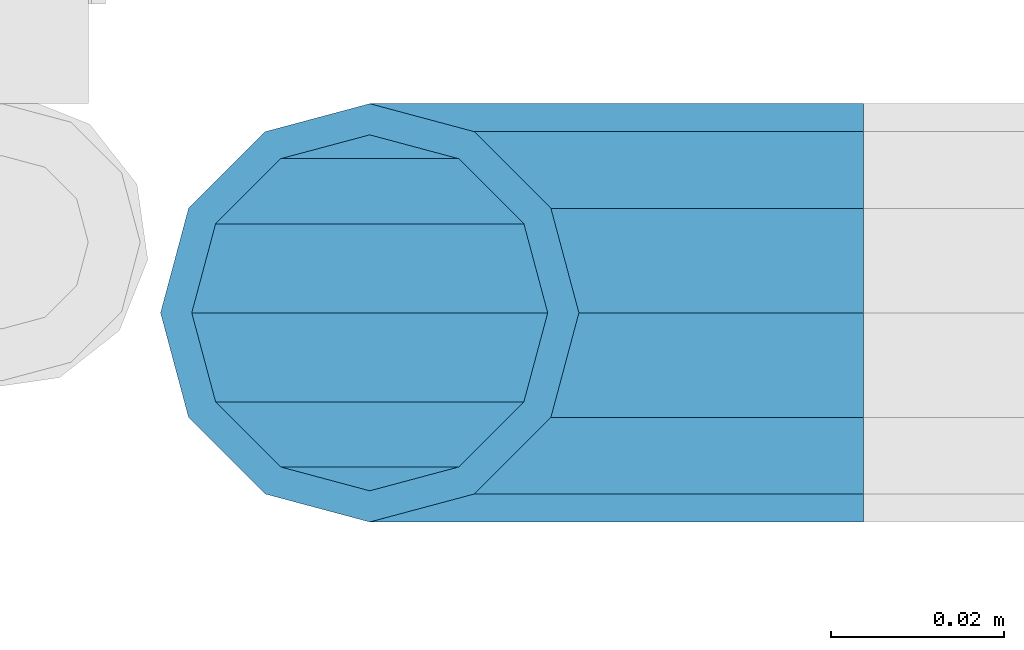
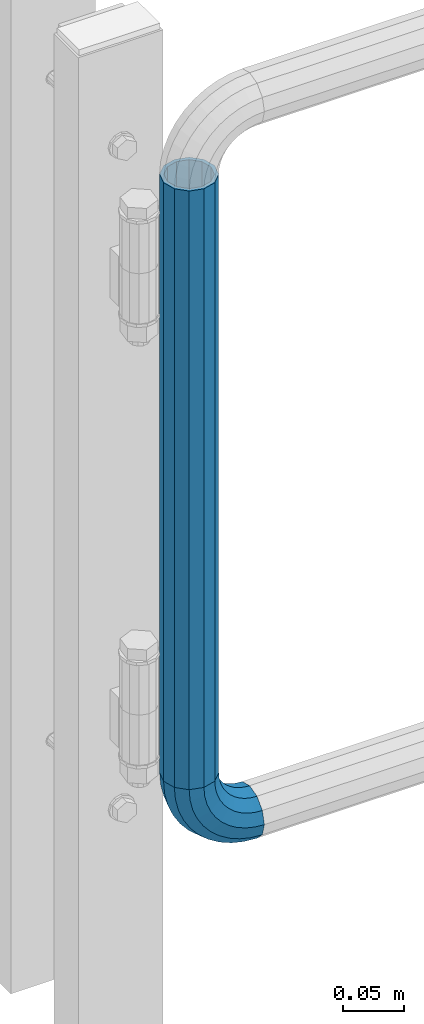
# One storey, part 177 of 247: 1 beam, 1 member.
"""IFC2X3 building model written with IfcOpenShell, lengths in millimetres."""

from ifc_helpers import new_model, si_unit, frame, origin_with_axes, place, context, subcontext, project, spatial, faceted_brep, material, type_object, element, save


model = new_model("IFC2X3")

# Units and contexts
model_context = context("Model", 3, precision=1e-05, world=origin_with_axes())
body_context = subcontext(model_context, "Body", "Model", "MODEL_VIEW")
ifc_project = project(units=[si_unit("LENGTHUNIT", "METRE", prefix="MILLI"), si_unit("AREAUNIT", "SQUARE_METRE"), si_unit("VOLUMEUNIT", "CUBIC_METRE"), si_unit("MASSUNIT", "GRAM", prefix="KILO"), si_unit("TIMEUNIT", "SECOND"), si_unit("PLANEANGLEUNIT", "RADIAN"), si_unit("SOLIDANGLEUNIT", "STERADIAN"), si_unit("THERMODYNAMICTEMPERATUREUNIT", "DEGREE_CELSIUS"), si_unit("LUMINOUSINTENSITYUNIT", "LUMEN")], contexts=[model_context])

# Site, building, storey
site_placement = place(None, origin_with_axes())
site = spatial("IfcSite", under=ifc_project, at=site_placement, CompositionType="ELEMENT")
building_placement = place(site_placement, origin_with_axes())
building = spatial("IfcBuilding", under=site, at=building_placement, Name="Standard", CompositionType="ELEMENT")
storey_placement = place(building_placement, origin_with_axes())
storey = spatial("IfcBuildingStorey", under=building, at=storey_placement, Name="Undefined", CompositionType="ELEMENT", Elevation=0.0)

# Member
ifc_material = material()
member_type = type_object("IfcMemberType", PredefinedType="NOTDEFINED")
member_placement = place(storey_placement, frame((26955.2462679207, 8941.85337247848, 224.650000000007), z_axis=(0.0, -0.999999999999548, -9.5100000000016e-07), x_axis=(-0.707106789186492, 3.85000008583224e-07, 0.707106773186498)))
element("IfcMember", 1, at=member_placement, inside=storey, type_object=member_type, material=ifc_material, context=body_context, shape_type="Brep", body=[
    faceted_brep([(17.0766287656552, -17.0766287656515, 0.0), (14.7887943220521, -14.7887943220485, -12.0749999999998), (19.0945697419556, -11.1113146999705, -12.0749999999998), (20.9963409898264, -13.7288782624128, 0.0), (8.53831438282941, -8.53831438282577, -20.9145135013941), (13.8988340683936, -3.95999805533575, -20.9145135013941), (0.0, 3.63797880709171e-12, -24.1499999999996), (6.80132714696083, 5.80888215174127, -24.1499999999996), (-8.53831438282577, 8.53831438282941, -20.9145135013941), (-0.296179774468328, 15.5777623588219, -20.9145135013941), (-14.7887943220521, 14.7887943220558, -12.0749999999998), (-5.4919154480267, 22.7290790034531, -12.0749999999998), (-17.0766287656552, 17.0766287656588, 0.0), (-7.39368669590112, 25.3466425658989, 0.0), (-14.7887943220521, 14.7887943220558, 12.0749999999998), (-5.4919154480267, 22.7290790034531, 12.0749999999998), (-8.53831438282577, 8.53831438282941, 20.9145135013941), (-0.296179774468328, 15.5777623588219, 20.9145135013941), (0.0, 3.63797880709171e-12, 24.1499999999996), (6.80132714696083, 5.80888215174127, 24.1499999999996), (8.53831438282941, -8.53831438282577, 20.9145135013941), (13.8988340683936, -3.95999805533575, 20.9145135013941), (14.7887943220521, -14.7887943220485, 12.0749999999998), (19.0945697419556, -11.1113146999705, 12.0749999999998), (14.5310443533854, -14.5310443533817, 0.0), (12.5842535535485, -12.5842535535448, 10.2749999999996), (17.2620366843148, -8.58904933077429, 10.2749999999996), (18.8803140815726, -10.8164170826603, 0.0), (7.26552217669087, -7.26552217668723, 17.7968220477705), (12.8408206142667, -2.50376746545953, 17.7968220477705), (0.0, 3.63797880709171e-12, 20.5500000000002), (6.80132714696083, 5.80888215174127, 20.5500000000002), (-7.26552217669087, 7.2655221766945, 17.7968220477705), (0.761833679654956, 14.1215317689421, 17.7968220477705), (-12.5842535535485, 12.5842535535521, 10.2749999999996), (-3.65938239038951, 20.2068136342532, 10.2749999999996), (-14.5310443533817, 14.5310443533854, 0.0), (-5.27765978764728, 22.4341813861465, 0.0), (-12.5842535535485, 12.5842535535521, -10.2749999999996), (-3.65938239038951, 20.2068136342532, -10.2749999999996), (-7.26552217669087, 7.2655221766945, -17.7968220477705), (0.761833679654956, 14.1215317689421, -17.7968220477705), (0.0, 3.63797880709171e-12, -20.5500000000002), (6.80132714696083, 5.80888215174127, -20.5500000000002), (7.26552217669087, -7.26552217668723, -17.7968220477705), (12.8408206142667, -2.50376746545953, -17.7968220477705), (12.5842535535485, -12.5842535535448, -10.2749999999996), (17.2620366843148, -8.58904933077429, -10.2749999999996), (23.922618478784, -8.15268262886457, -12.0749999999998), (25.3914986111849, -11.0355222080434, 0.0), (19.9095633268335, -0.276618428470101, -20.9145135013941), (14.4276280424783, 10.4822853511068, -24.1499999999996), (8.94569275812319, 21.2411891306838, -20.9145135013941), (4.93263760616901, 29.1172533310746, -12.0749999999998), (3.46375747376806, 32.0000929102534, 0.0), (4.93263760616901, 29.1172533310746, 12.0749999999998), (8.94569275812319, 21.2411891306838, 20.9145135013941), (14.4276280424783, 10.4822853511068, 24.1499999999996), (19.9095633268335, -0.276618428470101, 20.9145135013941), (23.922618478784, -8.15268262886457, 12.0749999999998), (22.5072161777207, -5.37479920327678, 10.2749999999996), (23.7571328121303, -7.82789872096328, 0.0), (19.0923804273007, 1.32719331506814, 17.7968220477705), (14.4276280424783, 10.4822853511068, 20.5500000000002), (9.76287565765597, 19.6373773871455, 17.7968220477705), (6.34803990723594, 26.3393699054905, 10.2749999999996), (5.09812327282998, 28.7924694231733, 0.0), (6.34803990723594, 26.3393699054905, -10.2749999999996), (9.76287565765597, 19.6373773871455, -17.7968220477705), (14.4276280424783, 10.4822853511068, -20.5500000000002), (19.0923804273007, 1.32719331506814, -17.7968220477705), (22.5072161777207, -5.37479920327678, -10.2749999999996), (29.1540579492757, -5.98574944944994, -12.0749999999998), (30.1538782624157, -9.0628799673359, 0.0), (26.4224980553372, 2.42112746692874, -20.9145135013941), (22.6911178482587, 13.9051349011934, -24.1499999999996), (18.9597376411839, 25.3891423354544, -20.9145135013941), (16.228177747249, 33.7960192518367, -12.0749999999998), (15.2283574341054, 36.873149769719, 0.0), (16.228177747249, 33.7960192518367, 12.0749999999998), (18.9597376411839, 25.3891423354544, 20.9145135013941), (22.6911178482587, 13.9051349011934, 24.1499999999996), (26.4224980553372, 2.42112746692874, 20.9145135013941), (29.1540579492757, -5.98574944944994, 12.0749999999998), (28.190638306889, -3.02064867668378, 10.2749999999996), (29.0414170826662, -5.63907650866895, 0.0), (25.8662674654624, 4.13302919626221, 17.7968220477705), (22.6911178482587, 13.9051349011934, 20.5500000000002), (19.5159682310587, 23.6772406061282, 17.7968220477705), (17.1915973896357, 30.8309184790705, 10.2749999999996), (16.3408186138549, 33.4493463110593, 0.0), (17.1915973896357, 30.8309184790705, -10.2749999999996), (19.5159682310587, 23.6772406061282, -17.7968220477705), (22.6911178482587, 13.9051349011934, -20.5500000000002), (25.8662674654624, 4.13302919626221, -17.7968220477705), (28.190638306889, -3.02064867668378, -10.2749999999996), (34.660072751507, -4.66387224825303, -12.0749999999998), (35.1662143510621, -7.85952453907885, 0.0), (33.2772681857023, 4.06681217360529, -20.9145135013941), (31.3883220203388, 15.9931488862931, -24.1499999999996), (29.499375854979, 27.9194855989772, -20.9145135013941), (28.1165712891707, 36.6501700208391, -12.0749999999998), (27.6104296896192, 39.8458223116686, 0.0), (28.1165712891707, 36.6501700208391, 12.0749999999998), (29.499375854979, 27.9194855989772, 20.9145135013941), (31.3883220203388, 15.9931488862931, 24.1499999999996), (33.2772681857023, 4.06681217360529, 20.9145135013941), (34.660072751507, -4.66387224825303, 12.0749999999998), (34.1723583567982, -1.58456474993727, 10.2749999999996), (34.6030502769172, -4.30384651293571, 0.0), (32.995686148628, 5.84465118667504, 17.7968220477705), (31.3883220203388, 15.9931488862931, 20.5500000000002), (29.7809578920533, 26.1416465859074, 17.7968220477705), (28.6042856838794, 33.5708625225234, 10.2749999999996), (28.1735937637641, 36.2901442855255, 0.0), (28.6042856838794, 33.5708625225234, -10.2749999999996), (29.7809578920533, 26.1416465859074, -17.7968220477705), (31.3883220203388, 15.9931488862931, -20.5500000000002), (32.995686148628, 5.84465118667504, -17.7968220477705), (34.1723583567982, -1.58456474993727, -10.2749999999996), (40.3050865276309, -4.21960002902415, -12.0749999999998), (40.3050865276346, -7.45508652763237, 0.0), (40.3050865276309, 4.61991347236835, -20.9145135013941), (40.3050865276346, 16.6949134723691, -24.1499999999996), (40.3050865276309, 28.7699134723698, -20.9145135013941), (40.3050865276309, 37.6094269737623, -12.0749999999998), (40.3050865276346, 40.8449134723705, 0.0), (40.3050865276309, 37.6094269737623, 12.0749999999998), (40.3050865276309, 28.7699134723698, 20.9145135013941), (40.3050865276346, 16.6949134723691, 24.1499999999996), (40.3050865276309, 4.61991347236835, 20.9145135013941), (40.3050865276309, -4.21960002902415, 12.0749999999998), (40.3050865276346, -1.10190857540147, 10.2749999999996), (40.3050865276309, -3.85508652763019, 0.0), (40.3050865276346, 6.41991347236763, 17.7968220477705), (40.3050865276346, 16.6949134723691, 20.5500000000002), (40.3050865276346, 26.9699134723705, 17.7968220477705), (40.3050865276346, 34.4917355201396, 10.2749999999996), (40.3050865276309, 37.2449134723684, 0.0), (40.3050865276346, 34.4917355201396, -10.2749999999996), (40.3050865276346, 26.9699134723705, -17.7968220477705), (40.3050865276346, 16.6949134723691, -20.5500000000002), (40.3050865276346, 6.41991347236763, -17.7968220477705), (40.3050865276346, -1.10190857540147, -10.2749999999996), (45.9501003037585, -4.66387224825667, -12.0749999999998), (45.443958704207, -7.85952453907885, 0.0), (47.3329048695668, 4.06681217360529, -20.9145135013941), (49.2218510349267, 15.9931488862894, -24.1499999999996), (51.1107972002865, 27.9194855989808, -20.9145135013941), (52.4936017660912, 36.6501700208391, -12.0749999999998), (52.9997433656463, 39.845822311665, 0.0), (52.4936017660912, 36.6501700208391, 12.0749999999998), (51.1107972002865, 27.9194855989808, 20.9145135013941), (49.2218510349267, 15.9931488862894, 24.1499999999996), (47.3329048695668, 4.06681217360529, 20.9145135013941), (45.9501003037585, -4.66387224825667, 12.0749999999998), (46.4378146984673, -1.58456474993363, 10.2749999999996), (46.0071227783483, -4.30384651293934, 0.0), (47.6144869066338, 5.84465118667504, 17.7968220477705), (49.2218510349267, 15.9931488862894, 20.5500000000002), (50.8292151632122, 26.1416465859038, 17.7968220477705), (52.0058873713861, 33.5708625225197, 10.2749999999996), (52.4365792915014, 36.2901442855218, 0.0), (52.0058873713861, 33.5708625225197, -10.2749999999996), (50.8292151632122, 26.1416465859038, -17.7968220477705), (49.2218510349267, 15.9931488862894, -20.5500000000002), (47.6144869066338, 5.84465118667504, -17.7968220477705), (46.4378146984673, -1.58456474993363, -10.2749999999996), (51.4561151059934, -5.98574944944994, -12.0749999999998), (50.4562947928498, -9.06287996733226, 0.0), (54.1876749999246, 2.42112746692874, -20.9145135013941), (57.9190552070031, 13.9051349011934, -24.1499999999996), (61.6504354140816, 25.389142335458, -20.9145135013941), (64.3819953080201, 33.7960192518367, -12.0749999999998), (65.3818156211564, 36.873149769719, 0.0), (64.3819953080201, 33.7960192518367, 12.0749999999998), (61.6504354140816, 25.389142335458, 20.9145135013941), (57.9190552070031, 13.9051349011934, 24.1499999999996), (54.1876749999246, 2.42112746692874, 20.9145135013941), (51.4561151059934, -5.98574944944994, 12.0749999999998), (52.4195347483801, -3.02064867668378, 10.2749999999996), (51.5687559725993, -5.63907650867259, 0.0), (54.743905589803, 4.13302919625858, 17.7968220477705), (57.9190552070031, 13.9051349011934, 20.5500000000002), (61.0942048242068, 23.6772406061245, 17.7968220477705), (63.4185756656334, 30.8309184790705, 10.2749999999996), (64.2693544414105, 33.4493463110557, 0.0), (63.4185756656334, 30.8309184790705, -10.2749999999996), (61.0942048242068, 23.6772406061245, -17.7968220477705), (57.9190552070031, 13.9051349011934, -20.5500000000002), (54.743905589803, 4.13302919625858, -17.7968220477705), (52.4195347483801, -3.02064867668378, -10.2749999999996), (56.6875545764815, -8.15268262886093, -12.0749999999998), (55.2186744440769, -11.0355222080434, 0.0), (60.700609728432, -0.276618428466463, -20.9145135013941), (66.1825450127908, 10.4822853511068, -24.1499999999996), (71.6644802971423, 21.2411891306801, -20.9145135013941), (75.6775354490928, 29.1172533310746, -12.0749999999998), (77.1464155814938, 32.0000929102534, 0.0), (75.6775354490928, 29.1172533310746, 12.0749999999998), (71.6644802971423, 21.2411891306801, 20.9145135013941), (66.1825450127908, 10.4822853511068, 24.1499999999996), (60.700609728432, -0.276618428466463, 20.9145135013941), (56.6875545764815, -8.15268262886093, 12.0749999999998), (58.1029568775448, -5.37479920327314, 10.2749999999996), (56.8530402431388, -7.82789872096328, 0.0), (61.5177926279612, 1.32719331506814, 17.7968220477705), (66.1825450127908, 10.4822853511068, 20.5500000000002), (70.8472973976095, 19.6373773871419, 17.7968220477705), (74.2621331480295, 26.3393699054868, 10.2749999999996), (75.5120497824355, 28.792469423177, 0.0), (74.2621331480295, 26.3393699054868, -10.2749999999996), (70.8472973976095, 19.6373773871419, -17.7968220477705), (66.1825450127908, 10.4822853511068, -20.5500000000002), (61.5177926279612, 1.32719331506814, -17.7968220477705), (58.1029568775448, -5.37479920327314, -10.2749999999996), (61.5156033133135, -11.1113146999705, -12.0749999999998), (59.6138320654427, -13.7288782624128, 0.0), (66.7113389868719, -3.95999805533938, -20.9145135013941), (73.8088459083046, 5.80888215174491, -24.1499999999996), (80.9063528297338, 15.5777623588183, -20.9145135013941), (86.1020885032958, 22.7290790034531, -12.0749999999998), (88.0038597511666, 25.3466425658953, 0.0), (86.1020885032958, 22.7290790034531, 12.0749999999998), (80.9063528297338, 15.5777623588183, 20.9145135013941), (73.8088459083046, 5.80888215174491, 24.1499999999996), (66.7113389868719, -3.95999805533938, 20.9145135013941), (61.5156033133135, -11.1113146999705, 12.0749999999998), (63.3481363709507, -8.58904933077065, 10.2749999999996), (61.7298589736929, -10.816417082664, 0.0), (67.7693524410024, -2.50376746545953, 17.7968220477705), (73.8088459083046, 5.80888215174491, 20.5500000000002), (79.8483393756105, 14.1215317689457, 17.7968220477705), (84.2695554456586, 20.2068136342532, 10.2749999999996), (85.8878328429164, 22.4341813861465, 0.0), (84.2695554456586, 20.2068136342532, -10.2749999999996), (79.8483393756105, 14.1215317689457, -17.7968220477705), (73.8088459083046, 5.80888215174491, -20.5500000000002), (67.7693524410024, -2.50376746545953, -17.7968220477705), (63.3481363709507, -8.58904933077065, -10.2749999999996), (65.8213787332134, -14.7887943220521, -12.0749999999998), (63.5335442896103, -17.0766287656552, 0.0), (72.0718586724397, -8.53831438282577, -20.9145135013941), (80.6101730552655, 0.0, -24.1499999999996), (89.1484874380949, 8.53831438282941, -20.9145135013941), (95.3989673773212, 14.7887943220558, -12.0749999999998), (97.6868018209243, 17.0766287656588, 0.0), (95.3989673773212, 14.7887943220558, 12.0749999999998), (89.1484874380949, 8.53831438282941, 20.9145135013941), (80.6101730552655, 0.0, 24.1499999999996), (72.0718586724397, -8.53831438282577, 20.9145135013941), (65.8213787332134, -14.7887943220521, 12.0749999999998), (68.025919501717, -12.5842535535485, 10.2749999999996), (66.0791287018837, -14.5310443533817, 0.0), (73.3446508785746, -7.26552217669087, 17.7968220477705), (80.6101730552655, 0.0, 20.5500000000002), (87.87569523196, 7.2655221766945, 17.7968220477705), (93.1944266088176, 12.5842535535521, 10.2749999999996), (95.1412174086508, 14.5310443533854, 0.0), (93.1944266088176, 12.5842535535521, -10.2749999999996), (87.87569523196, 7.2655221766945, -17.7968220477705), (80.6101730552655, 0.0, -20.5500000000002), (73.3446508785746, -7.26552217669087, -17.7968220477705), (68.025919501717, -12.5842535535485, -10.2749999999996)], [[[0, 1, 2, 3]], [[1, 4, 5, 2]], [[4, 6, 7, 5]], [[6, 8, 9, 7]], [[8, 10, 11, 9]], [[10, 12, 13, 11]], [[12, 14, 15, 13]], [[14, 16, 17, 15]], [[16, 18, 19, 17]], [[18, 20, 21, 19]], [[20, 22, 23, 21]], [[22, 0, 3, 23]], [[24, 25, 26, 27]], [[25, 28, 29, 26]], [[28, 30, 31, 29]], [[30, 32, 33, 31]], [[32, 34, 35, 33]], [[34, 36, 37, 35]], [[36, 38, 39, 37]], [[38, 40, 41, 39]], [[40, 42, 43, 41]], [[42, 44, 45, 43]], [[44, 46, 47, 45]], [[46, 24, 27, 47]], [[22, 20, 18, 16, 14, 12, 10, 8, 6, 4, 1, 0], [46, 44, 42, 40, 38, 36, 34, 32, 30, 28, 25, 24]], [[3, 2, 48, 49]], [[2, 5, 50, 48]], [[5, 7, 51, 50]], [[7, 9, 52, 51]], [[9, 11, 53, 52]], [[11, 13, 54, 53]], [[13, 15, 55, 54]], [[15, 17, 56, 55]], [[17, 19, 57, 56]], [[19, 21, 58, 57]], [[21, 23, 59, 58]], [[23, 3, 49, 59]], [[27, 26, 60, 61]], [[26, 29, 62, 60]], [[29, 31, 63, 62]], [[31, 33, 64, 63]], [[33, 35, 65, 64]], [[35, 37, 66, 65]], [[37, 39, 67, 66]], [[39, 41, 68, 67]], [[41, 43, 69, 68]], [[43, 45, 70, 69]], [[45, 47, 71, 70]], [[47, 27, 61, 71]], [[49, 48, 72, 73]], [[48, 50, 74, 72]], [[50, 51, 75, 74]], [[51, 52, 76, 75]], [[52, 53, 77, 76]], [[53, 54, 78, 77]], [[54, 55, 79, 78]], [[55, 56, 80, 79]], [[56, 57, 81, 80]], [[57, 58, 82, 81]], [[58, 59, 83, 82]], [[59, 49, 73, 83]], [[61, 60, 84, 85]], [[60, 62, 86, 84]], [[62, 63, 87, 86]], [[63, 64, 88, 87]], [[64, 65, 89, 88]], [[65, 66, 90, 89]], [[66, 67, 91, 90]], [[67, 68, 92, 91]], [[68, 69, 93, 92]], [[69, 70, 94, 93]], [[70, 71, 95, 94]], [[71, 61, 85, 95]], [[73, 72, 96, 97]], [[72, 74, 98, 96]], [[74, 75, 99, 98]], [[75, 76, 100, 99]], [[76, 77, 101, 100]], [[77, 78, 102, 101]], [[78, 79, 103, 102]], [[79, 80, 104, 103]], [[80, 81, 105, 104]], [[81, 82, 106, 105]], [[82, 83, 107, 106]], [[83, 73, 97, 107]], [[85, 84, 108, 109]], [[84, 86, 110, 108]], [[86, 87, 111, 110]], [[87, 88, 112, 111]], [[88, 89, 113, 112]], [[89, 90, 114, 113]], [[90, 91, 115, 114]], [[91, 92, 116, 115]], [[92, 93, 117, 116]], [[93, 94, 118, 117]], [[94, 95, 119, 118]], [[95, 85, 109, 119]], [[97, 96, 120, 121]], [[96, 98, 122, 120]], [[98, 99, 123, 122]], [[99, 100, 124, 123]], [[100, 101, 125, 124]], [[101, 102, 126, 125]], [[102, 103, 127, 126]], [[103, 104, 128, 127]], [[104, 105, 129, 128]], [[105, 106, 130, 129]], [[106, 107, 131, 130]], [[107, 97, 121, 131]], [[109, 108, 132, 133]], [[108, 110, 134, 132]], [[110, 111, 135, 134]], [[111, 112, 136, 135]], [[112, 113, 137, 136]], [[113, 114, 138, 137]], [[114, 115, 139, 138]], [[115, 116, 140, 139]], [[116, 117, 141, 140]], [[117, 118, 142, 141]], [[118, 119, 143, 142]], [[119, 109, 133, 143]], [[121, 120, 144, 145]], [[120, 122, 146, 144]], [[122, 123, 147, 146]], [[123, 124, 148, 147]], [[124, 125, 149, 148]], [[125, 126, 150, 149]], [[126, 127, 151, 150]], [[127, 128, 152, 151]], [[128, 129, 153, 152]], [[129, 130, 154, 153]], [[130, 131, 155, 154]], [[131, 121, 145, 155]], [[133, 132, 156, 157]], [[132, 134, 158, 156]], [[134, 135, 159, 158]], [[135, 136, 160, 159]], [[136, 137, 161, 160]], [[137, 138, 162, 161]], [[138, 139, 163, 162]], [[139, 140, 164, 163]], [[140, 141, 165, 164]], [[141, 142, 166, 165]], [[142, 143, 167, 166]], [[143, 133, 157, 167]], [[145, 144, 168, 169]], [[144, 146, 170, 168]], [[146, 147, 171, 170]], [[147, 148, 172, 171]], [[148, 149, 173, 172]], [[149, 150, 174, 173]], [[150, 151, 175, 174]], [[151, 152, 176, 175]], [[152, 153, 177, 176]], [[153, 154, 178, 177]], [[154, 155, 179, 178]], [[155, 145, 169, 179]], [[157, 156, 180, 181]], [[156, 158, 182, 180]], [[158, 159, 183, 182]], [[159, 160, 184, 183]], [[160, 161, 185, 184]], [[161, 162, 186, 185]], [[162, 163, 187, 186]], [[163, 164, 188, 187]], [[164, 165, 189, 188]], [[165, 166, 190, 189]], [[166, 167, 191, 190]], [[167, 157, 181, 191]], [[169, 168, 192, 193]], [[168, 170, 194, 192]], [[170, 171, 195, 194]], [[171, 172, 196, 195]], [[172, 173, 197, 196]], [[173, 174, 198, 197]], [[174, 175, 199, 198]], [[175, 176, 200, 199]], [[176, 177, 201, 200]], [[177, 178, 202, 201]], [[178, 179, 203, 202]], [[179, 169, 193, 203]], [[181, 180, 204, 205]], [[180, 182, 206, 204]], [[182, 183, 207, 206]], [[183, 184, 208, 207]], [[184, 185, 209, 208]], [[185, 186, 210, 209]], [[186, 187, 211, 210]], [[187, 188, 212, 211]], [[188, 189, 213, 212]], [[189, 190, 214, 213]], [[190, 191, 215, 214]], [[191, 181, 205, 215]], [[193, 192, 216, 217]], [[192, 194, 218, 216]], [[194, 195, 219, 218]], [[195, 196, 220, 219]], [[196, 197, 221, 220]], [[197, 198, 222, 221]], [[198, 199, 223, 222]], [[199, 200, 224, 223]], [[200, 201, 225, 224]], [[201, 202, 226, 225]], [[202, 203, 227, 226]], [[203, 193, 217, 227]], [[205, 204, 228, 229]], [[204, 206, 230, 228]], [[206, 207, 231, 230]], [[207, 208, 232, 231]], [[208, 209, 233, 232]], [[209, 210, 234, 233]], [[210, 211, 235, 234]], [[211, 212, 236, 235]], [[212, 213, 237, 236]], [[213, 214, 238, 237]], [[214, 215, 239, 238]], [[215, 205, 229, 239]], [[217, 216, 240, 241]], [[216, 218, 242, 240]], [[218, 219, 243, 242]], [[219, 220, 244, 243]], [[220, 221, 245, 244]], [[221, 222, 246, 245]], [[222, 223, 247, 246]], [[223, 224, 248, 247]], [[224, 225, 249, 248]], [[225, 226, 250, 249]], [[226, 227, 251, 250]], [[227, 217, 241, 251]], [[229, 228, 252, 253]], [[228, 230, 254, 252]], [[230, 231, 255, 254]], [[231, 232, 256, 255]], [[232, 233, 257, 256]], [[233, 234, 258, 257]], [[234, 235, 259, 258]], [[235, 236, 260, 259]], [[236, 237, 261, 260]], [[237, 238, 262, 261]], [[238, 239, 263, 262]], [[239, 229, 253, 263]], [[242, 243, 244, 245, 246, 247, 248, 249, 250, 251, 241, 240], [254, 255, 256, 257, 258, 259, 260, 261, 262, 263, 253, 252]]]),
])

# Beam
beam_type = type_object("IfcBeamType", PredefinedType="NOTDEFINED")
beam_placement = place(storey_placement, frame((26898.2462613762, 8941.85337247848, 878.350006544462), z_axis=(1.0, 0.0, 0.0), x_axis=(0.0, 0.0, -1.0)))
element("IfcBeam", 2, at=beam_placement, inside=storey, type_object=beam_type, material=ifc_material, context=body_context, shape_type="Brep", body=[
    faceted_brep([(0.0, -20.5500000000002, 0.0), (0.0, -17.7968220477705, 10.2750000000015), (596.700000000001, -17.7968220477705, 10.2750000000015), (596.700000000001, -20.5500000000002, 0.0), (0.0, -10.2749999999996, 17.7968220477705), (596.700000000001, -10.2749999999996, 17.7968220477705), (0.0, 3.63797880709171e-12, 20.5500000000002), (596.700000000001, 0.0, 20.5499999999993), (0.0, 10.2749999999996, 17.7968220477705), (596.700000000001, 10.2749999999996, 17.7968220477705), (0.0, 17.7968220477705, 10.2750000000015), (596.700000000001, 17.7968220477705, 10.2750000000015), (0.0, 20.5500000000002, 0.0), (596.700000000001, 20.5500000000002, 0.0), (0.0, 17.7968220477705, -10.2750000000015), (596.700000000001, 17.7968220477705, -10.2750000000015), (0.0, 10.2749999999996, -17.7968220477705), (596.700000000001, 10.2749999999996, -17.7968220477705), (0.0, 3.63797880709171e-12, -20.5500000000002), (596.700000000001, 0.0, -20.5499999999993), (0.0, -10.2749999999996, -17.7968220477705), (596.700000000001, -10.2749999999996, -17.7968220477705), (0.0, -17.7968220477705, -10.2750000000015), (596.700000000001, -17.7968220477705, -10.2750000000015), (0.0, -24.1499999999996, 0.0), (0.0, -20.9145135013941, -12.0750000000007), (596.700000000001, -20.9145135013941, -12.0750000000007), (596.700000000001, -24.1499999999996, 0.0), (0.0, -12.0749999999998, -20.9145135013932), (596.700000000001, -12.0749999999998, -20.9145135013932), (0.0, 3.63797880709171e-12, -24.1499999999996), (596.700000000001, 0.0, -24.1500000000015), (0.0, 12.0749999999998, -20.9145135013932), (596.700000000001, 12.0749999999998, -20.9145135013932), (0.0, 20.9145135013941, -12.0750000000007), (596.700000000001, 20.9145135013941, -12.0750000000007), (0.0, 24.1499999999996, 0.0), (596.700000000001, 24.1499999999996, 0.0), (0.0, 20.9145135013941, 12.0750000000007), (596.700000000001, 20.9145135013941, 12.0750000000007), (0.0, 12.0749999999998, 20.9145135013932), (596.700000000001, 12.0749999999998, 20.9145135013932), (0.0, 3.63797880709171e-12, 24.1499999999996), (596.700000000001, 0.0, 24.1500000000015), (0.0, -12.0749999999998, 20.9145135013932), (596.700000000001, -12.0749999999998, 20.9145135013932), (0.0, -20.9145135013941, 12.0750000000007), (596.700000000001, -20.9145135013941, 12.0750000000007)], [[[0, 1, 2, 3]], [[1, 4, 5, 2]], [[4, 6, 7, 5]], [[6, 8, 9, 7]], [[8, 10, 11, 9]], [[10, 12, 13, 11]], [[12, 14, 15, 13]], [[14, 16, 17, 15]], [[16, 18, 19, 17]], [[18, 20, 21, 19]], [[20, 22, 23, 21]], [[22, 0, 3, 23]], [[24, 25, 26, 27]], [[25, 28, 29, 26]], [[28, 30, 31, 29]], [[30, 32, 33, 31]], [[32, 34, 35, 33]], [[34, 36, 37, 35]], [[36, 38, 39, 37]], [[38, 40, 41, 39]], [[40, 42, 43, 41]], [[42, 44, 45, 43]], [[44, 46, 47, 45]], [[46, 24, 27, 47]], [[29, 31, 33, 35, 37, 39, 41, 43, 45, 47, 27, 26], [5, 7, 9, 11, 13, 15, 17, 19, 21, 23, 3, 2]], [[46, 44, 42, 40, 38, 36, 34, 32, 30, 28, 25, 24], [22, 20, 18, 16, 14, 12, 10, 8, 6, 4, 1, 0]]]),
])

save(model, "model.ifc")
